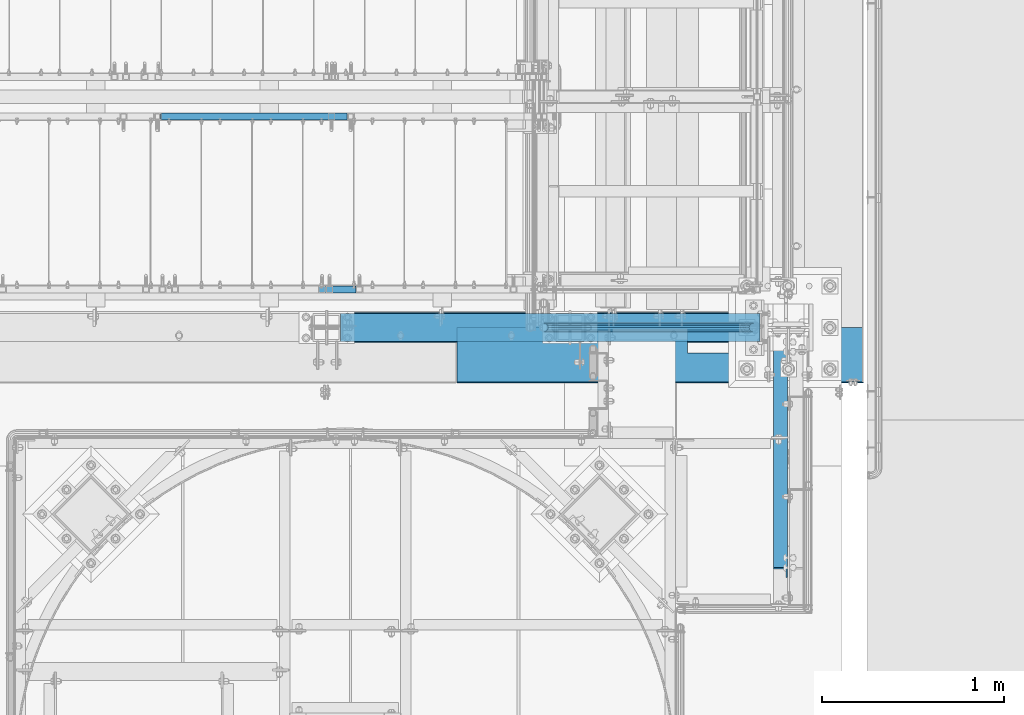
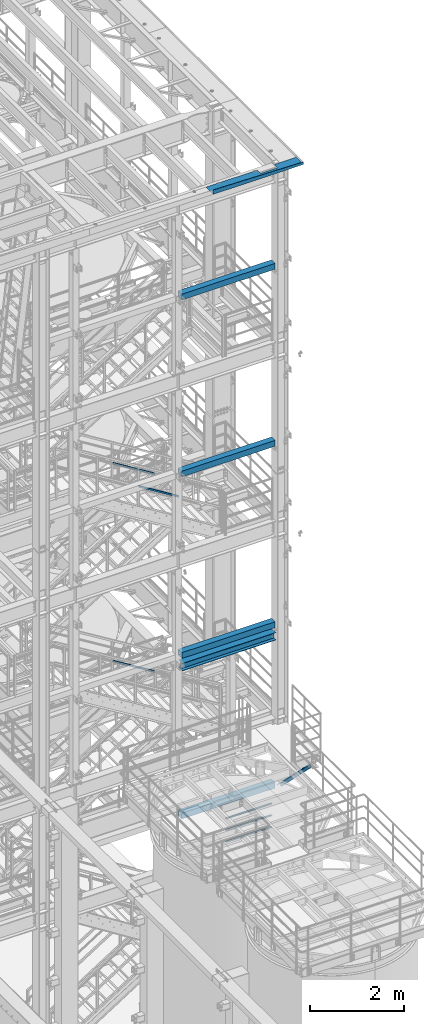
# One storey, part 948 of 1876: 9 beams, 4 members, 11 elements without a shape of their own.
"""IFC2X3 building model written with IfcOpenShell, lengths in millimetres."""

from ifc_helpers import new_model, si_unit, frame, origin_with_axes, place, context, subcontext, project, spatial, faceted_brep, material, type_object, element, aggregate, save


model = new_model("IFC2X3")

# Units and contexts
model_context = context("Model", 3, precision=1e-05, world=origin_with_axes())
body_context = subcontext(model_context, "Body", "Model", "MODEL_VIEW")
ifc_project = project(units=[si_unit("LENGTHUNIT", "METRE", prefix="MILLI"), si_unit("AREAUNIT", "SQUARE_METRE"), si_unit("VOLUMEUNIT", "CUBIC_METRE"), si_unit("MASSUNIT", "GRAM", prefix="KILO"), si_unit("TIMEUNIT", "SECOND"), si_unit("PLANEANGLEUNIT", "RADIAN"), si_unit("SOLIDANGLEUNIT", "STERADIAN"), si_unit("THERMODYNAMICTEMPERATUREUNIT", "DEGREE_CELSIUS"), si_unit("LUMINOUSINTENSITYUNIT", "LUMEN")], contexts=[model_context])

# Site, building, storey
site_placement = place(None, origin_with_axes())
site = spatial("IfcSite", under=ifc_project, at=site_placement, CompositionType="ELEMENT")
building_placement = place(site_placement, origin_with_axes())
building = spatial("IfcBuilding", under=site, at=building_placement, Name="Undefined", CompositionType="ELEMENT")
storey_placement = place(building_placement, origin_with_axes())
storey = spatial("IfcBuildingStorey", under=building, at=storey_placement, Name="Undefined", CompositionType="ELEMENT", Elevation=0.0)

# Assembly, beams
assembly_1_placement = place(storey_placement, origin_with_axes())
assembly_1 = element("IfcElementAssembly", 1, at=assembly_1_placement, inside=storey, Name="RAIL", AssemblyPlace="NOTDEFINED", PredefinedType="RIGID_FRAME")
ifc_material_1 = material()
beam_type_1 = type_object("IfcBeamType", Name="PIPE1-1/2SCH40", PredefinedType="NOTDEFINED")
beam_1_placement = place(assembly_1_placement, frame((7427.9125, -7112.0, 5292.72499999999), z_axis=(0.0, 0.0, 1.0), x_axis=(-1.0, 0.0, 0.0)))
beam_1 = element("IfcBeam", 2, at=beam_1_placement, type_object=beam_type_1, material=ifc_material_1, Name="RAIL", ObjectType="PIPE1-1/2SCH40", context=body_context, shape_type="Brep", body=[
    faceted_brep([(1133.21514289765, -12.0649999999996, 20.8971929933186), (1133.21514289765, -12.0649999999996, 15.8661214311805), (1132.72171445979, -10.2235000000001, 17.7076214311801), (1129.98233589097, 0.0, 20.4470000000001), (1129.98233589097, 0.0, 24.1300000000001), (1132.72171445979, 10.2235000000001, 17.7076214311801), (1133.21514289765, 12.0649999999996, 15.8661214311805), (1133.21514289765, 12.0649999999996, 20.8971929933186), (1154.11233589097, 24.1300000000001, 0.0), (1142.04733589097, 20.8971929933186, 12.0649999999996), (1142.04733589097, 20.8971929933186, -12.0649999999996), (1138.85776432883, 17.7076214311801, 10.2235000000001), (1141.59714289765, 20.4470000000001, 0.0), (1138.85776432883, 17.7076214311801, -10.2235000000001), (1133.21514289765, 12.0649999999996, -15.8661214311805), (1133.21514289765, 12.0649999999996, -20.8971929933186), (1132.72171445979, 10.2235000000001, -17.7076214311801), (1129.98233589097, 0.0, -20.4470000000001), (1129.98233589097, 0.0, -24.1300000000001), (1133.21514289765, -12.0649999999996, -15.8661214311805), (1133.21514289765, -12.0649999999996, -20.8971929933186), (1132.72171445979, -10.2235000000001, -17.7076214311801), (1154.11233589097, -24.1300000000001, 0.0), (1142.04733589097, -20.8971929933186, -12.0649999999996), (1142.04733589097, -20.8971929933186, 12.0649999999996), (1138.85776432883, -17.7076214311801, -10.2235000000001), (1141.59714289765, -20.4470000000001, 0.0), (1138.85776432883, -17.7076214311801, 10.2235000000001), (12.0650000000064, -20.8971929933177, -12.0649999999987), (20.8971929933249, -12.0650000000005, -20.8971929933177), (0.0, 24.1299999999992, 0.0), (12.0650000000064, 20.8971929933177, -12.0649999999987), (12.0650000000064, 20.8971929933177, 12.0649999999987), (20.8971929933249, 12.0650000000005, 20.8971929933177), (24.1300000000064, 0.0, 24.130000000001), (20.8971929933249, 12.0650000000005, -20.8971929933177), (24.1300000000063, 0.0, -24.130000000001), (24.1300000000063, 0.0, -20.4470000000001), (20.8971929933249, -12.0650000000005, -15.8661214311796), (21.3906214311868, -10.2235000000001, -17.7076214311819), (21.3906214311868, 10.2235000000001, -17.7076214311819), (20.8971929933249, 12.0650000000005, -15.8661214311796), (15.2545715621445, 17.7076214311801, -10.2235000000001), (12.5151929933249, 20.4470000000001, 0.0), (15.2545715621445, 17.7076214311801, 10.2235000000001), (20.8971929933249, 12.0650000000005, 15.8661214311796), (21.3906214311868, 10.2235000000001, 17.7076214311819), (24.1300000000064, 0.0, 20.4470000000001), (21.3906214311868, -10.2235000000001, 17.7076214311819), (20.8971929933249, -12.0650000000005, 15.8661214311796), (20.8971929933249, -12.0650000000005, 20.8971929933177), (12.0650000000064, -20.8971929933177, 12.0649999999987), (0.0, -24.1299999999992, 0.0), (15.2545715621445, -17.7076214311801, 10.2235000000001), (12.5151929933249, -20.4470000000001, 0.0), (15.2545715621445, -17.7076214311801, -10.2235000000001)], [[[0, 1, 2, 3, 4]], [[4, 3, 5, 6, 7]], [[8, 9, 10]], [[7, 6, 11, 12, 13, 14, 15, 10, 9]], [[16, 17, 18, 15, 14]], [[19, 20, 18, 17, 21]], [[22, 23, 24]], [[24, 23, 20, 19, 25, 26, 27, 1, 0]], [[28, 29, 20, 23]], [[30, 31, 32]], [[33, 34, 4, 7]], [[32, 33, 7, 9]], [[30, 32, 9, 8]], [[31, 30, 8, 10]], [[35, 31, 10, 15]], [[36, 35, 15, 18]], [[29, 36, 18, 20]], [[37, 36, 29, 38, 39]], [[40, 41, 35, 36, 37]], [[32, 31, 35, 41, 42, 43, 44, 45, 33]], [[33, 45, 46, 47, 34]], [[34, 47, 48, 49, 50]], [[34, 50, 0, 4]], [[50, 51, 24, 0]], [[51, 52, 22, 24]], [[52, 28, 23, 22]], [[51, 28, 52]], [[50, 49, 53, 54, 55, 38, 29, 28, 51]], [[55, 54, 26, 25]], [[21, 39, 38, 55, 25, 19]], [[37, 39, 21, 17]], [[40, 37, 17, 16]], [[42, 41, 40, 16, 14, 13]], [[43, 42, 13, 12]], [[44, 43, 12, 11]], [[5, 46, 45, 44, 11, 6]], [[47, 46, 5, 3]], [[48, 47, 3, 2]], [[53, 49, 48, 2, 1, 27]], [[54, 53, 27, 26]]]),
])
beam_2_placement = place(assembly_1_placement, frame((6273.80016410903, -7112.0, 5597.52499999999), z_axis=(0.0, 0.0, -1.0), x_axis=(1.0, 0.0, 0.0)))
beam_2 = element("IfcBeam", 3, at=beam_2_placement, type_object=beam_type_1, material=ifc_material_1, Name="RAIL", ObjectType="PIPE1-1/2SCH40", context=body_context, shape_type="Brep", body=[
    faceted_brep([(0.0, 24.1299999999992, 0.0), (12.0650000000064, 20.8971929933177, -12.0649999999987), (12.0650000000064, 20.8971929933177, 12.0649999999987), (12.0650000000064, -20.8971929933177, 12.0649999999987), (12.0650000000064, -20.8971929933177, -12.0649999999987), (0.0, -24.1299999999992, 0.0), (20.8971929933249, -12.0650000000005, 20.8971929933177), (20.8971929933249, -12.0650000000005, 15.8661214311796), (15.2545715621445, -17.7076214311801, 10.2235000000001), (12.5151929933249, -20.4470000000001, 0.0), (15.2545715621445, -17.7076214311801, -10.2235000000001), (20.8971929933249, -12.0650000000005, -15.8661214311796), (20.8971929933249, -12.0650000000005, -20.8971929933177), (24.1300000000063, 0.0, -20.4470000000001), (24.1300000000063, 0.0, -24.130000000001), (21.3906214311868, -10.2235000000001, -17.7076214311819), (21.3906214311868, 10.2235000000001, -17.7076214311819), (20.8971929933249, 12.0650000000005, -15.8661214311796), (20.8971929933249, 12.0650000000005, -20.8971929933177), (15.2545715621445, 17.7076214311801, -10.2235000000001), (12.5151929933249, 20.4470000000001, 0.0), (15.2545715621445, 17.7076214311801, 10.2235000000001), (20.8971929933249, 12.0650000000005, 15.8661214311796), (20.8971929933249, 12.0650000000005, 20.8971929933177), (21.3906214311868, 10.2235000000001, 17.7076214311819), (24.1300000000064, 0.0, 20.4470000000001), (24.1300000000064, 0.0, 24.130000000001), (21.3906214311868, -10.2235000000001, 17.7076214311819), (1154.11233589097, 24.1300000000001, 0.0), (1142.04733589097, 20.8971929933186, -12.0649999999996), (1133.21514289765, 12.0649999999996, -20.8971929933186), (1154.11233589097, -24.1300000000001, 0.0), (1142.04733589097, -20.8971929933186, -12.0649999999996), (1142.04733589097, -20.8971929933186, 12.0649999999996), (1133.21514289765, -12.0649999999996, 20.8971929933186), (1133.21514289765, -12.0649999999996, -20.8971929933186), (1129.98233589097, 0.0, -24.1300000000001), (1132.72171445979, 10.2235000000001, -17.7076214311801), (1129.98233589097, 0.0, -20.4470000000001), (1133.21514289765, 12.0649999999996, -15.8661214311805), (1133.21514289765, -12.0649999999996, -15.8661214311805), (1132.72171445979, -10.2235000000001, -17.7076214311801), (1138.85776432883, -17.7076214311801, -10.2235000000001), (1141.59714289765, -20.4470000000001, 0.0), (1138.85776432883, -17.7076214311801, 10.2235000000001), (1133.21514289765, -12.0649999999996, 15.8661214311805), (1132.72171445979, -10.2235000000001, 17.7076214311801), (1129.98233589097, 0.0, 20.4470000000001), (1129.98233589097, 0.0, 24.1300000000001), (1133.21514289765, 12.0649999999996, 20.8971929933186), (1142.04733589097, 20.8971929933186, 12.0649999999996), (1133.21514289765, 12.0649999999996, 15.8661214311805), (1138.85776432883, 17.7076214311801, 10.2235000000001), (1141.59714289765, 20.4470000000001, 0.0), (1138.85776432883, 17.7076214311801, -10.2235000000001), (1132.72171445979, 10.2235000000001, 17.7076214311801)], [[[0, 1, 2]], [[3, 4, 5]], [[6, 7, 8, 9, 10, 11, 12, 4, 3]], [[13, 14, 12, 11, 15]], [[16, 17, 18, 14, 13]], [[2, 1, 18, 17, 19, 20, 21, 22, 23]], [[23, 22, 24, 25, 26]], [[26, 25, 27, 7, 6]], [[1, 0, 28, 29]], [[18, 1, 29, 30]], [[31, 32, 33]], [[6, 3, 33, 34]], [[3, 5, 31, 33]], [[5, 4, 32, 31]], [[4, 12, 35, 32]], [[12, 14, 36, 35]], [[14, 18, 30, 36]], [[37, 38, 36, 30, 39]], [[40, 35, 36, 38, 41]], [[33, 32, 35, 40, 42, 43, 44, 45, 34]], [[34, 45, 46, 47, 48]], [[26, 6, 34, 48]], [[2, 23, 49, 50]], [[23, 26, 48, 49]], [[0, 2, 50, 28]], [[28, 50, 29]], [[49, 51, 52, 53, 54, 39, 30, 29, 50]], [[48, 47, 55, 51, 49]], [[25, 24, 55, 47]], [[55, 24, 22, 21, 52, 51]], [[21, 20, 53, 52]], [[20, 19, 54, 53]], [[19, 17, 16, 37, 39, 54]], [[16, 13, 38, 37]], [[13, 15, 41, 38]], [[41, 15, 11, 10, 42, 40]], [[10, 9, 43, 42]], [[9, 8, 44, 43]], [[8, 7, 27, 46, 45, 44]], [[27, 25, 47, 46]]]),
])
beam_3_placement = place(assembly_1_placement, frame((6273.80016410903, -7112.0, 5902.32499999999), z_axis=(0.0, 0.0, -1.0), x_axis=(1.0, 0.0, 0.0)))
beam_3 = element("IfcBeam", 4, at=beam_3_placement, type_object=beam_type_1, material=ifc_material_1, Name="RAIL", ObjectType="PIPE1-1/2SCH40", context=body_context, shape_type="Brep", body=[
    faceted_brep([(0.0, 24.1299999999992, 0.0), (12.0650000000064, 20.8971929933177, -12.0649999999987), (12.0650000000064, 20.8971929933177, 12.0649999999987), (12.0650000000064, -20.8971929933177, 12.0649999999987), (12.0650000000064, -20.8971929933177, -12.0649999999987), (0.0, -24.1299999999992, 0.0), (20.8971929933249, -12.0650000000005, 20.8971929933177), (20.8971929933249, -12.0650000000005, 15.8661214311796), (15.2545715621445, -17.7076214311801, 10.2235000000001), (12.5151929933249, -20.4470000000001, 0.0), (15.2545715621445, -17.7076214311801, -10.2235000000001), (20.8971929933249, -12.0650000000005, -15.8661214311796), (20.8971929933249, -12.0650000000005, -20.8971929933177), (24.1300000000063, 0.0, -20.4470000000001), (24.1300000000063, 0.0, -24.130000000001), (21.3906214311868, -10.2235000000001, -17.7076214311819), (21.3906214311868, 10.2235000000001, -17.7076214311819), (20.8971929933249, 12.0650000000005, -15.8661214311796), (20.8971929933249, 12.0650000000005, -20.8971929933177), (15.2545715621445, 17.7076214311801, -10.2235000000001), (12.5151929933249, 20.4470000000001, 0.0), (15.2545715621445, 17.7076214311801, 10.2235000000001), (20.8971929933249, 12.0650000000005, 15.8661214311796), (20.8971929933249, 12.0650000000005, 20.8971929933177), (21.3906214311868, 10.2235000000001, 17.7076214311819), (24.1300000000064, 0.0, 20.4470000000001), (24.1300000000064, 0.0, 24.130000000001), (21.3906214311868, -10.2235000000001, 17.7076214311819), (1154.11233589097, 24.1300000000001, 0.0), (1142.04733589097, 20.8971929933186, -12.0649999999996), (1133.21514289765, 12.0649999999996, -20.8971929933186), (1154.11233589097, -24.1300000000001, 0.0), (1142.04733589097, -20.8971929933186, -12.0649999999996), (1142.04733589097, -20.8971929933186, 12.0649999999996), (1133.21514289765, -12.0649999999996, 20.8971929933186), (1133.21514289765, -12.0649999999996, -20.8971929933186), (1129.98233589097, 0.0, -24.1300000000001), (1132.72171445979, 10.2235000000001, -17.7076214311801), (1129.98233589097, 0.0, -20.4470000000001), (1133.21514289765, 12.0649999999996, -15.8661214311805), (1133.21514289765, -12.0649999999996, -15.8661214311805), (1132.72171445979, -10.2235000000001, -17.7076214311801), (1138.85776432883, -17.7076214311801, -10.2235000000001), (1141.59714289765, -20.4470000000001, 0.0), (1138.85776432883, -17.7076214311801, 10.2235000000001), (1133.21514289765, -12.0649999999996, 15.8661214311805), (1132.72171445979, -10.2235000000001, 17.7076214311801), (1129.98233589097, 0.0, 20.4470000000001), (1129.98233589097, 0.0, 24.1300000000001), (1133.21514289765, 12.0649999999996, 20.8971929933186), (1142.04733589097, 20.8971929933186, 12.0649999999996), (1133.21514289765, 12.0649999999996, 15.8661214311805), (1138.85776432883, 17.7076214311801, 10.2235000000001), (1141.59714289765, 20.4470000000001, 0.0), (1138.85776432883, 17.7076214311801, -10.2235000000001), (1132.72171445979, 10.2235000000001, 17.7076214311801)], [[[0, 1, 2]], [[3, 4, 5]], [[6, 7, 8, 9, 10, 11, 12, 4, 3]], [[13, 14, 12, 11, 15]], [[16, 17, 18, 14, 13]], [[2, 1, 18, 17, 19, 20, 21, 22, 23]], [[23, 22, 24, 25, 26]], [[26, 25, 27, 7, 6]], [[1, 0, 28, 29]], [[18, 1, 29, 30]], [[31, 32, 33]], [[6, 3, 33, 34]], [[3, 5, 31, 33]], [[5, 4, 32, 31]], [[4, 12, 35, 32]], [[12, 14, 36, 35]], [[14, 18, 30, 36]], [[37, 38, 36, 30, 39]], [[40, 35, 36, 38, 41]], [[33, 32, 35, 40, 42, 43, 44, 45, 34]], [[34, 45, 46, 47, 48]], [[26, 6, 34, 48]], [[2, 23, 49, 50]], [[23, 26, 48, 49]], [[0, 2, 50, 28]], [[28, 50, 29]], [[49, 51, 52, 53, 54, 39, 30, 29, 50]], [[48, 47, 55, 51, 49]], [[25, 24, 55, 47]], [[55, 24, 22, 21, 52, 51]], [[21, 20, 53, 52]], [[20, 19, 54, 53]], [[19, 17, 16, 37, 39, 54]], [[16, 13, 38, 37]], [[13, 15, 41, 38]], [[41, 15, 11, 10, 42, 40]], [[10, 9, 43, 42]], [[9, 8, 44, 43]], [[8, 7, 27, 46, 45, 44]], [[27, 25, 47, 46]]]),
])
aggregate(assembly_1, [beam_1, beam_2, beam_3])

# Assembly, beam
assembly_2_placement = place(storey_placement, origin_with_axes())
assembly_2 = element("IfcElementAssembly", 5, at=assembly_2_placement, inside=storey, Name="FRAME", AssemblyPlace="NOTDEFINED", PredefinedType="RIGID_FRAME")
ifc_material_2 = material()
beam_type_2 = type_object("IfcBeamType", Name="HSS6X6X3/8", PredefinedType="NOTDEFINED")
beam_4_placement = place(assembly_2_placement, frame((5080.0, -7112.0, 19958.05), z_axis=(0.0, 1.0, 0.0), x_axis=(1.0, 0.0, 0.0)))
beam_4 = element("IfcBeam", 6, at=beam_4_placement, type_object=beam_type_2, material=ifc_material_2, Name="BEAM", ObjectType="HSS6X6X3/8", context=body_context, shape_type="Brep", body=[
    faceted_brep([(76.2000000000007, 66.6749999999993, -66.6750000000002), (76.2000000000007, -66.6749999999993, -66.6750000000002), (2382.8375, -66.6749999999993, -66.6750000000002), (2382.8375, 66.6749999999993, -66.6750000000002), (76.2000000000007, -66.6749999999993, 66.6750000000002), (2382.8375, -66.6749999999993, 66.6750000000002), (76.2000000000007, 66.6749999999993, 66.6750000000002), (2382.8375, 66.6749999999993, 66.6750000000002), (76.2000000000007, 76.2000000000007, -76.1999999999998), (76.2000000000007, 76.2000000000007, 76.1999999999998), (2382.8375, 76.2000000000007, 76.1999999999998), (2382.8375, 76.2000000000007, -76.1999999999998), (76.2000000000007, -76.2000000000007, 76.1999999999998), (2382.8375, -76.2000000000007, 76.1999999999998), (76.2000000000007, -76.2000000000007, -76.1999999999998), (2382.8375, -76.2000000000007, -76.1999999999998)], [[[0, 1, 2, 3]], [[1, 4, 5, 2]], [[4, 6, 7, 5]], [[6, 0, 3, 7]], [[8, 9, 10, 11]], [[9, 12, 13, 10]], [[12, 14, 15, 13]], [[14, 8, 11, 15]], [[13, 15, 11, 10], [5, 7, 3, 2]], [[14, 12, 9, 8], [6, 4, 1, 0]]]),
])
aggregate(assembly_2, [beam_4])

assembly_3_placement = place(storey_placement, origin_with_axes())
assembly_3 = element("IfcElementAssembly", 7, at=assembly_3_placement, inside=storey, Name="FRAME", AssemblyPlace="NOTDEFINED", PredefinedType="RIGID_FRAME")
beam_5_placement = place(assembly_3_placement, frame((5080.0, -7112.0, 15335.25), z_axis=(0.0, 1.0, 0.0), x_axis=(1.0, 0.0, 0.0)))
beam_5 = element("IfcBeam", 8, at=beam_5_placement, type_object=beam_type_2, material=ifc_material_2, Name="BEAM", ObjectType="HSS6X6X3/8", context=body_context, shape_type="Brep", body=[
    faceted_brep([(76.2000000000007, 66.6749999999993, -66.6750000000002), (76.2000000000007, -66.6749999999993, -66.6750000000002), (2382.8375, -66.6749999999993, -66.6750000000002), (2382.8375, 66.6749999999993, -66.6750000000002), (76.2000000000007, -66.6749999999993, 66.6750000000002), (2382.8375, -66.6749999999993, 66.6750000000002), (76.2000000000007, 66.6749999999993, 66.6750000000002), (2382.8375, 66.6749999999993, 66.6750000000002), (76.2000000000007, 76.2000000000007, -76.1999999999998), (76.2000000000007, 76.2000000000007, 76.1999999999998), (2382.8375, 76.2000000000007, 76.1999999999998), (2382.8375, 76.2000000000007, -76.1999999999998), (76.2000000000007, -76.2000000000007, 76.1999999999998), (2382.8375, -76.2000000000007, 76.1999999999998), (76.2000000000007, -76.2000000000007, -76.1999999999998), (2382.8375, -76.2000000000007, -76.1999999999998)], [[[0, 1, 2, 3]], [[1, 4, 5, 2]], [[4, 6, 7, 5]], [[6, 0, 3, 7]], [[8, 9, 10, 11]], [[9, 12, 13, 10]], [[12, 14, 15, 13]], [[14, 8, 11, 15]], [[13, 15, 11, 10], [5, 7, 3, 2]], [[14, 12, 9, 8], [6, 4, 1, 0]]]),
])
aggregate(assembly_3, [beam_5])

assembly_4_placement = place(storey_placement, origin_with_axes())
assembly_4 = element("IfcElementAssembly", 9, at=assembly_4_placement, inside=storey, Name="FRAME", AssemblyPlace="NOTDEFINED", PredefinedType="RIGID_FRAME")
beam_6_placement = place(assembly_4_placement, frame((5080.0, -7112.0, 10598.15), z_axis=(0.0, 1.0, 0.0), x_axis=(1.0, 0.0, 0.0)))
beam_6 = element("IfcBeam", 10, at=beam_6_placement, type_object=beam_type_2, material=ifc_material_2, Name="BEAM", ObjectType="HSS6X6X3/8", context=body_context, shape_type="Brep", body=[
    faceted_brep([(76.2000000000007, 66.6749999999993, -66.6750000000002), (76.2000000000007, -66.6749999999993, -66.6750000000002), (2382.8375, -66.6749999999993, -66.6750000000002), (2382.8375, 66.6749999999993, -66.6750000000002), (76.2000000000007, -66.6749999999993, 66.6750000000002), (2382.8375, -66.6749999999993, 66.6750000000002), (76.2000000000007, 66.6749999999993, 66.6750000000002), (2382.8375, 66.6749999999993, 66.6750000000002), (76.2000000000007, 76.2000000000007, -76.1999999999998), (76.2000000000007, 76.2000000000007, 76.1999999999998), (2382.8375, 76.2000000000007, 76.1999999999998), (2382.8375, 76.2000000000007, -76.1999999999998), (76.2000000000007, -76.2000000000007, 76.1999999999998), (2382.8375, -76.2000000000007, 76.1999999999998), (76.2000000000007, -76.2000000000007, -76.1999999999998), (2382.8375, -76.2000000000007, -76.1999999999998)], [[[0, 1, 2, 3]], [[1, 4, 5, 2]], [[4, 6, 7, 5]], [[6, 0, 3, 7]], [[8, 9, 10, 11]], [[9, 12, 13, 10]], [[12, 14, 15, 13]], [[14, 8, 11, 15]], [[13, 15, 11, 10], [5, 7, 3, 2]], [[14, 12, 9, 8], [6, 4, 1, 0]]]),
])
aggregate(assembly_4, [beam_6])

assembly_5_placement = place(storey_placement, origin_with_axes())
assembly_5 = element("IfcElementAssembly", 11, at=assembly_5_placement, inside=storey, Name="FRAME", AssemblyPlace="NOTDEFINED", PredefinedType="RIGID_FRAME")
beam_7_placement = place(assembly_5_placement, frame((5079.98075746042, -7112.0, 6407.15001063849), z_axis=(0.0, 1.0, 0.0), x_axis=(1.0, 0.0, 0.0)))
beam_7 = element("IfcBeam", 12, at=beam_7_placement, type_object=beam_type_2, material=ifc_material_2, Name="BEAM", ObjectType="HSS6X6X3/8", context=body_context, shape_type="Brep", body=[
    faceted_brep([(76.2192425395833, 66.6750000000002, -66.6750000000002), (76.2192425395833, -66.6750000000002, -66.6750000000002), (2382.8375, -66.6749999999993, -66.6750000000002), (2382.8375, 66.6749999999993, -66.6750000000002), (76.2192425395833, -66.6750000000002, 66.6750000000002), (2382.8375, -66.6749999999993, 66.6750000000002), (76.2192425395833, 66.6750000000002, 66.6750000000002), (2382.8375, 66.6749999999993, 66.6750000000002), (76.2192425395833, 76.1999999999998, -76.1999999999998), (76.2192425395833, 76.1999999999998, 76.1999999999998), (2382.8375, 76.2000000000007, 76.1999999999998), (2382.8375, 76.2000000000007, -76.1999999999998), (76.2192425395833, -76.1999999999998, 76.1999999999998), (2382.8375, -76.2000000000007, 76.1999999999998), (76.2192425395833, -76.1999999999998, -76.1999999999998), (2382.8375, -76.2000000000007, -76.1999999999998)], [[[0, 1, 2, 3]], [[1, 4, 5, 2]], [[4, 6, 7, 5]], [[6, 0, 3, 7]], [[8, 9, 10, 11]], [[9, 12, 13, 10]], [[12, 14, 15, 13]], [[14, 8, 11, 15]], [[13, 15, 11, 10], [5, 7, 3, 2]], [[14, 12, 9, 8], [6, 4, 1, 0]]]),
])
aggregate(assembly_5, [beam_7])

assembly_6_placement = place(storey_placement, origin_with_axes())
assembly_6 = element("IfcElementAssembly", 13, at=assembly_6_placement, inside=storey, Name="BEAM", AssemblyPlace="NOTDEFINED", PredefinedType="RIGID_FRAME")
ifc_material_3 = material(Name="STEEL/A992")
beam_type_3 = type_object("IfcBeamType", Name="W8X24", PredefinedType="NOTDEFINED")
beam_8_placement = place(assembly_6_placement, frame((5156.2, -7112.0, 10294.9375), z_axis=(0.0, 0.0, 1.0), x_axis=(1.0, 0.0, 0.0)))
beam_8 = element("IfcBeam", 14, at=beam_8_placement, type_object=beam_type_3, material=ifc_material_3, Name="BEAM", ObjectType="W8X24", context=body_context, shape_type="Brep", body=[
    faceted_brep([(10.0000000000018, 82.5500000000002, -100.012500000001), (10.0000000000018, 82.5500000000002, -90.4874999999993), (2318.8625, 82.5500000000002, -90.4874999999993), (2318.8625, 82.5500000000002, -100.012500000001), (10.0000000000018, 3.17500000000018, -90.4874999999993), (2318.8625, 3.17500000000018, -90.4874999999993), (10.0000000000018, 3.17500000000018, 90.4874999999993), (2318.8625, 3.17500000000018, 90.4874999999993), (10.0000000000018, 82.5500000000002, 90.4874999999993), (2318.8625, 82.5500000000002, 90.4874999999993), (10.0000000000018, 82.5500000000002, 100.012500000001), (2318.8625, 82.5500000000002, 100.012500000001), (10.0000000000018, -82.5500000000002, 100.012500000001), (2318.8625, -82.5500000000002, 100.012500000001), (10.0000000000018, -82.5500000000002, 90.4874999999993), (2318.8625, -82.5500000000002, 90.4874999999993), (10.0000000000018, -3.17500000000018, 90.4874999999993), (2318.8625, -3.17500000000018, 90.4874999999993), (10.0000000000018, -3.17500000000018, -90.4874999999993), (2318.8625, -3.17500000000018, -90.4874999999993), (10.0000000000018, -82.5500000000002, -90.4874999999993), (2318.8625, -82.5500000000002, -90.4874999999993), (10.0000000000018, -82.5500000000002, -100.012500000001), (2318.8625, -82.5500000000002, -100.012500000001)], [[[0, 1, 2, 3]], [[1, 4, 5, 2]], [[4, 6, 7, 5]], [[6, 8, 9, 7]], [[8, 10, 11, 9]], [[10, 12, 13, 11]], [[12, 14, 15, 13]], [[14, 16, 17, 15]], [[16, 18, 19, 17]], [[18, 20, 21, 19]], [[20, 22, 23, 21]], [[22, 0, 3, 23]], [[5, 7, 9, 11, 13, 15, 17, 19, 21, 23, 3, 2]], [[22, 20, 18, 16, 14, 12, 10, 8, 6, 4, 1, 0]]]),
])
aggregate(assembly_6, [beam_8])

# Assembly, member
assembly_7_placement = place(storey_placement, origin_with_axes())
assembly_7 = element("IfcElementAssembly", 15, at=assembly_7_placement, inside=storey, Name="ANGLE", AssemblyPlace="NOTDEFINED", PredefinedType="RIGID_FRAME")
ifc_material_4 = material(Name="STEEL/A36")
member_type_1 = type_object("IfcMemberType", Name="L3X3X3/8", PredefinedType="NOTDEFINED")
member_1_placement = place(assembly_7_placement, frame((7577.13749994663, -7164.38750000517, 6345.23749999955), z_axis=(-1.0, 0.0, 0.0), x_axis=(0.0, -0.707106781186548, 0.707106781186548)))
member_1 = element("IfcMember", 16, at=member_1_placement, type_object=member_type_1, material=ifc_material_4, Name="ANGLE", ObjectType="L3X3X3/8", context=body_context, shape_type="Brep", body=[
    faceted_brep([(0.0, 38.1000000000004, -38.1), (0.0, 38.1000000000004, 38.1), (1831.97224869938, 38.1000000000057, 38.1000000000004), (1831.97224869938, 38.1000000000057, -38.1000000000004), (0.0, 28.5749999999998, 38.1), (1831.97224869938, 28.5750000000043, 38.1000000000004), (0.0, 28.5749999999998, -28.575), (1831.97224869938, 28.5750000000043, -28.5749999999998), (0.0, -38.1000000000004, -28.575), (1831.97224869938, -38.1000000000068, -28.5749999999998), (0.0, -38.1000000000004, -38.1), (1831.97224869938, -38.1000000000068, -38.1000000000004)], [[[0, 1, 2, 3]], [[1, 4, 5, 2]], [[4, 6, 7, 5]], [[6, 8, 9, 7]], [[8, 10, 11, 9]], [[10, 0, 3, 11]], [[5, 7, 9, 11, 3, 2]], [[10, 8, 6, 4, 1, 0]]]),
])
aggregate(assembly_7, [member_1])

assembly_8_placement = place(storey_placement, origin_with_axes())
assembly_8 = element("IfcElementAssembly", 17, at=assembly_8_placement, inside=storey, Name="RAIL", AssemblyPlace="NOTDEFINED", PredefinedType="RIGID_FRAME")
member_type_2 = type_object("IfcMemberType", Name="HSS1-1/2X1-1/2X1/8", PredefinedType="NOTDEFINED")
member_2_placement = place(assembly_8_placement, frame((5213.35000046757, -5949.95000114554, 9411.16554201711), z_axis=(0.523955482879573, 0.0, 0.851745649804232), x_axis=(-0.851745649804232, 0.0, 0.523955482879573)))
member_2 = element("IfcMember", 18, at=member_2_placement, type_object=member_type_2, material=ifc_material_2, Name="RAIL", ObjectType="HSS1-1/2X1-1/2X1/8", context=body_context, shape_type="Brep", body=[
    faceted_brep([(1234.38228196586, -19.0499992349996, 19.0499992361129), (1210.94501017189, -19.0499992349996, -19.0499992339264), (1210.94501017189, 19.0499992349996, -19.0499992339264), (1234.38228196586, 19.0499992349996, 19.0499992361129), (1232.42917593412, -15.8749992829999, 15.8749992841094), (1232.42917593412, 15.8749992829999, 15.8749992841094), (1212.89811620362, 15.8749992829999, -15.874999281923), (1212.89811620362, -15.8749992829999, -15.874999281923), (10.6471616099025, 19.0499992349996, -19.0499992350033), (34.0844334038557, 19.0499992349996, 19.0499992349978), (34.0844334038557, -19.0499992349996, 19.0499992349978), (10.6471616099025, -19.0499992349996, -19.0499992350033), (32.1313273721225, 15.8749992829999, 15.874999282998), (32.1313273721225, -15.8749992829999, 15.874999282998), (12.6002676416374, -15.8749992829999, -15.8749992830035), (12.6002676416374, 15.8749992829999, -15.8749992830035)], [[[0, 1, 2, 3], [4, 5, 6, 7]], [[8, 9, 3, 2]], [[9, 10, 0, 3]], [[10, 11, 1, 0]], [[11, 8, 2, 1]], [[11, 10, 9, 8], [12, 13, 14, 15]], [[14, 13, 4, 7]], [[15, 14, 7, 6]], [[12, 15, 6, 5]], [[13, 12, 5, 4]]]),
])
aggregate(assembly_8, [member_2])

assembly_9_placement = place(storey_placement, origin_with_axes())
assembly_9 = element("IfcElementAssembly", 19, at=assembly_9_placement, inside=storey, Name="RAIL", AssemblyPlace="NOTDEFINED", PredefinedType="RIGID_FRAME")
member_3_placement = place(assembly_9_placement, frame((5259.07000024152, -6902.45000114421, 14544.1226363948), z_axis=(0.5266503718289, 0.0, 0.850081987723821), x_axis=(-0.850081987723821, 0.0, 0.5266503718289)))
member_3 = element("IfcMember", 20, at=member_3_placement, type_object=member_type_2, material=ifc_material_2, Name="RAIL", ObjectType="HSS1-1/2X1-1/2X1/8", context=body_context, shape_type="Brep", body=[
    faceted_brep([(1183.07728369528, -19.0499992349996, 19.0499992347704), (1159.47323296761, -19.0499992349996, -19.0499992352379), (1159.47323296761, 19.0499992349996, -19.0499992352379), (1183.07728369528, 19.0499992349996, 19.0499992347704), (1181.11027941872, -15.8749992829999, 15.8749992827688), (1181.11027941872, 15.8749992829999, 15.8749992827688), (1161.44023724416, 15.8749992829999, -15.8749992832381), (1161.44023724416, -15.8749992829999, -15.8749992832381), (10.6075778003737, 19.0499992349996, -19.0499992350105), (34.2116285280431, 19.0499992349996, 19.0499992349996), (34.2116285280431, -19.0499992349996, 19.0499992349996), (10.6075778003737, -19.0499992349996, -19.0499992350105), (32.2446242514848, -15.8749992829999, 15.874999282998), (12.5745344275801, -15.8749992829999, -15.8749992829962), (12.5745344275801, 15.8749992829999, -15.8749992829962), (32.2446242514848, 15.8749992829999, 15.874999282998)], [[[0, 1, 2, 3], [4, 5, 6, 7]], [[8, 9, 3, 2]], [[9, 10, 0, 3]], [[10, 11, 1, 0]], [[11, 8, 2, 1]], [[10, 9, 8, 11], [12, 13, 14, 15]], [[13, 12, 4, 7]], [[14, 13, 7, 6]], [[15, 14, 6, 5]], [[12, 15, 5, 4]]]),
])
aggregate(assembly_9, [member_3])

assembly_10_placement = place(storey_placement, origin_with_axes())
assembly_10 = element("IfcElementAssembly", 21, at=assembly_10_placement, inside=storey, Name="RAIL", AssemblyPlace="NOTDEFINED", PredefinedType="RIGID_FRAME")
member_4_placement = place(assembly_10_placement, frame((5210.17500030023, -5949.95000114554, 14574.4145026763), z_axis=(0.5266503718289, 0.0, 0.850081987723821), x_axis=(-0.850081987723821, 0.0, 0.5266503718289)))
member_4 = element("IfcMember", 22, at=member_4_placement, type_object=member_type_2, material=ifc_material_2, Name="RAIL", ObjectType="HSS1-1/2X1-1/2X1/8", context=body_context, shape_type="Brep", body=[
    faceted_brep([(1240.59526507697, -19.0499992349996, 19.0499992347595), (1216.9912143493, -19.0499992349996, -19.0499992352488), (1216.9912143493, 19.0499992349996, -19.0499992352488), (1240.59526507697, 19.0499992349996, 19.0499992347595), (1238.62826080041, -15.8749992829999, 15.8749992827579), (1238.62826080041, 15.8749992829999, 15.8749992827579), (1218.95821862586, 15.8749992829999, -15.8749992832472), (1218.95821862586, -15.8749992829999, -15.8749992832472), (10.6075778003737, 19.0499992349996, -19.0499992350105), (34.2116285280431, 19.0499992349996, 19.0499992349996), (34.2116285280431, -19.0499992349996, 19.0499992349996), (10.6075778003737, -19.0499992349996, -19.0499992350105), (32.2446242514848, -15.8749992829999, 15.874999282998), (12.5745344275801, -15.8749992829999, -15.8749992829962), (12.5745344275801, 15.8749992829999, -15.8749992829962), (32.2446242514848, 15.8749992829999, 15.874999282998)], [[[0, 1, 2, 3], [4, 5, 6, 7]], [[8, 9, 3, 2]], [[9, 10, 0, 3]], [[10, 11, 1, 0]], [[11, 8, 2, 1]], [[10, 9, 8, 11], [12, 13, 14, 15]], [[13, 12, 4, 7]], [[14, 13, 7, 6]], [[15, 14, 6, 5]], [[12, 15, 5, 4]]]),
])
aggregate(assembly_10, [member_4])

# Assembly, beam
assembly_11_placement = place(storey_placement, origin_with_axes())
assembly_11 = element("IfcElementAssembly", 23, at=assembly_11_placement, inside=storey, Name="BENT PLATE", AssemblyPlace="NOTDEFINED", PredefinedType="RIGID_FRAME")
beam_type_4 = type_object("IfcBeamType", PredefinedType="NOTDEFINED")
beam_9_placement = place(assembly_11_placement, frame((6915.15, -7111.99997714219, 22558.3750000001), z_axis=(1.0, 0.0, 0.0), x_axis=(0.0, -0.999999999968684, -7.91400000071008e-06)))
beam_9 = element("IfcBeam", 24, at=beam_9_placement, type_object=beam_type_4, material=ifc_material_4, Name="BENT PLATE", context=body_context, shape_type="Brep", body=[
    faceted_brep([(139.699996952976, -3.17499995653634, 150.812493896481), (139.700042666626, 3.17500004346584, 150.812493896481), (-9.88620740827173e-10, 3.17499999999927, 150.812493896481), (9.877112461254e-10, -3.17499999999927, 150.812493896481), (139.699996952976, -3.17499995653634, 569.912499999997), (139.700042666626, 3.17500004346584, 569.912499999997), (9.877112461254e-10, -3.17499999999927, 569.912499999997), (-9.88620740827173e-10, 3.17499999999927, 569.912499999997), (304.799984210132, 3.1750000948341, -1117.6), (304.799984210132, 3.1750000948341, 1117.6), (304.799638092191, -63.3681985068906, 1117.6), (304.799394943264, -110.115002002654, -1117.6), (298.449951181138, -3.1749999071435, 1117.6), (298.449951181138, -3.1749999071435, -1117.6), (298.449394943347, -110.11496897375, -1117.6), (298.44963809234, -63.3681527932422, 1117.6), (-9.88620740827173e-10, 3.17499999999927, 1117.6), (9.877112461254e-10, -3.17499999999927, 1117.6), (9.877112461254e-10, -3.17499999999927, -1117.6), (-9.88620740827173e-10, 3.17499999999927, -1117.6)], [[[0, 1, 2, 3]], [[4, 5, 1, 0]], [[6, 7, 5, 4]], [[8, 9, 10, 11]], [[12, 13, 14, 15]], [[9, 16, 17, 12, 15, 10]], [[14, 11, 10, 15]], [[13, 18, 19, 8, 11, 14]], [[19, 18, 3, 2]], [[16, 9, 8, 19, 2, 1, 5, 7]], [[17, 16, 7, 6]], [[3, 18, 13, 12, 17, 6, 4, 0]]]),
])
aggregate(assembly_11, [beam_9])

save(model, "model.ifc")
